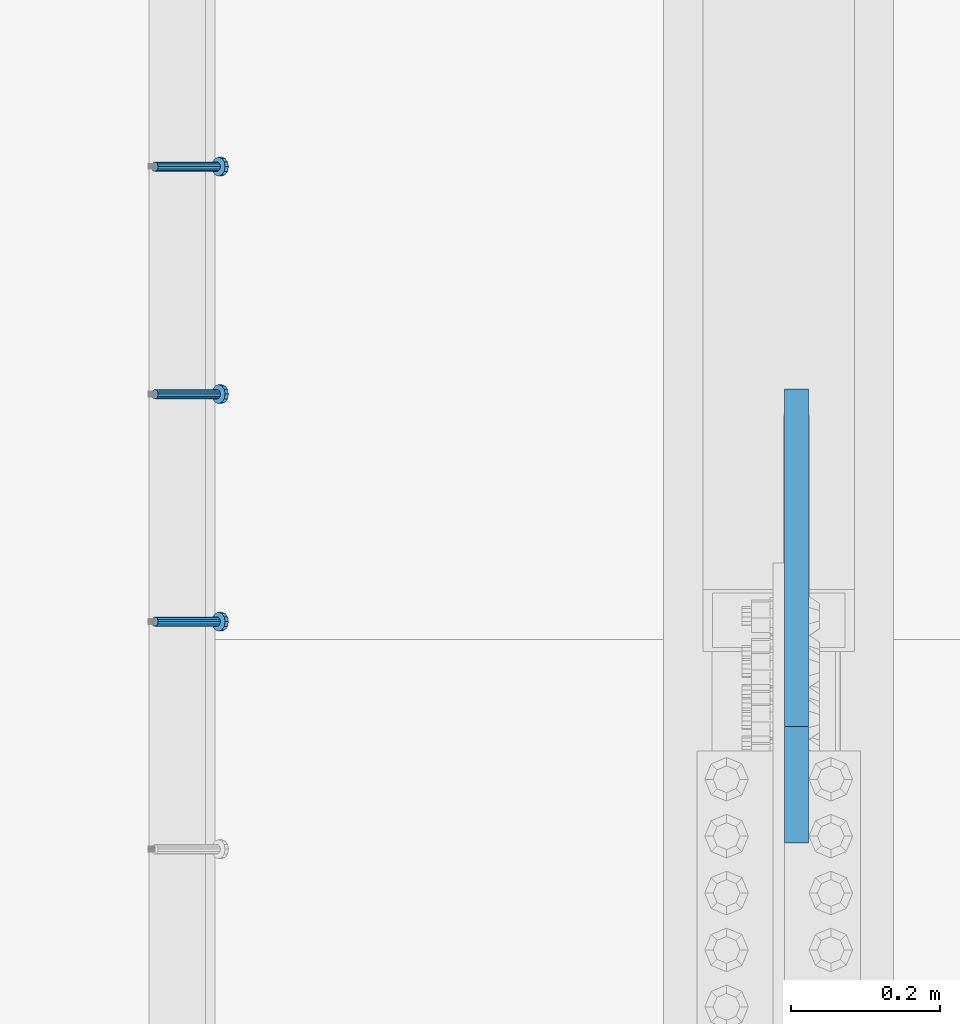
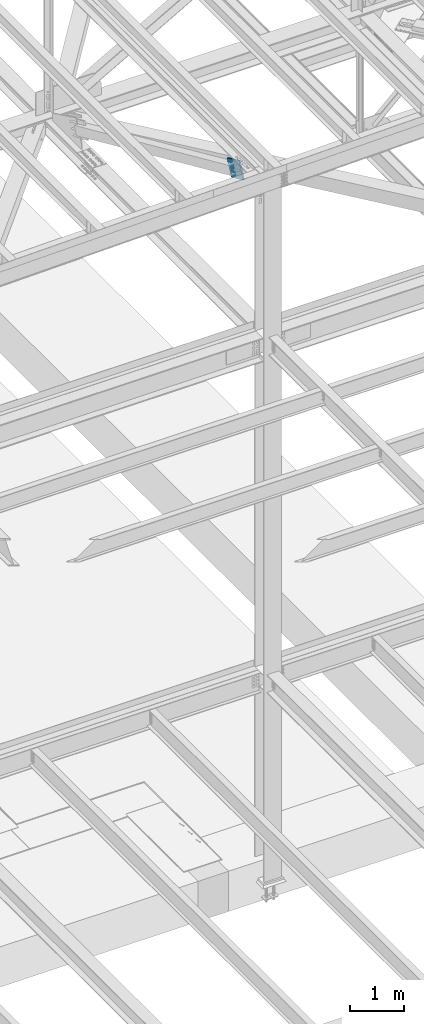
# One storey, part 2170 of 3843: 4 members, 2 elements without a shape of their own.
"""IFC2X3 building model written with IfcOpenShell, lengths in millimetres."""

from ifc_helpers import new_model, si_unit, frame, origin_with_axes, place, context, subcontext, project, spatial, faceted_brep, material, type_object, element, aggregate, save


model = new_model("IFC2X3")

# Units and contexts
model_context = context("Model", 3, precision=1e-05, world=origin_with_axes())
body_context = subcontext(model_context, "Body", "Model", "MODEL_VIEW")
ifc_project = project(units=[si_unit("LENGTHUNIT", "METRE", prefix="MILLI"), si_unit("AREAUNIT", "SQUARE_METRE"), si_unit("VOLUMEUNIT", "CUBIC_METRE"), si_unit("MASSUNIT", "GRAM", prefix="KILO"), si_unit("TIMEUNIT", "SECOND"), si_unit("PLANEANGLEUNIT", "RADIAN"), si_unit("SOLIDANGLEUNIT", "STERADIAN"), si_unit("THERMODYNAMICTEMPERATUREUNIT", "DEGREE_CELSIUS"), si_unit("LUMINOUSINTENSITYUNIT", "LUMEN")], contexts=[model_context])

# Site, building, storey
site_placement = place(None, origin_with_axes())
site = spatial("IfcSite", under=ifc_project, at=site_placement, CompositionType="ELEMENT")
building_placement = place(site_placement, origin_with_axes())
building = spatial("IfcBuilding", under=site, at=building_placement, Name="Undefined", CompositionType="ELEMENT")
storey_placement = place(building_placement, origin_with_axes())
storey = spatial("IfcBuildingStorey", under=building, at=storey_placement, Name="Undefined", CompositionType="ELEMENT", Elevation=0.0)

# Assembly, members
assembly_1_placement = place(storey_placement, origin_with_axes())
assembly_1 = element("IfcElementAssembly", 1, at=assembly_1_placement, inside=storey, Name="EMBED_ANGLE", AssemblyPlace="NOTDEFINED", PredefinedType="RIGID_FRAME")
ifc_material_1 = material(Name="STEEL/A108")
member_type_1 = type_object("IfcMemberType", PredefinedType="NOTDEFINED")
member_1_placement = place(assembly_1_placement, frame((69420.5494374184, 27458.9875018083, 30446.6625), z_axis=(0.0, 1.0, 0.0), x_axis=(0.707106781186548, 0.0, -0.707106781186548)))
member_1 = element("IfcMember", 2, at=member_1_placement, type_object=member_type_1, material=ifc_material_1, Name="HEADED STUD ANCHOR", context=body_context, shape_type="Brep", body=[
    faceted_brep([(7.27595761418343e-12, -3.18000006675175, 5.5), (0.0, -5.49999999998363, 3.1800000667572), (118.110000000976, -5.49999999999091, 3.1800000667572), (118.110000000983, -3.18000006675175, 5.5), (0.0, -6.3499999046162, 0.0), (118.110000000968, -6.34999990461256, 0.0), (0.0, -5.49999999998363, -3.1800000667572), (118.110000000976, -5.49999999999091, -3.1800000667572), (7.27595761418343e-12, -3.18000006675175, -5.5), (118.110000000983, -3.18000006675175, -5.5), (7.27595761418343e-12, -1.81898940354586e-12, -6.34999990463257), (118.110000000968, -1.81898940354586e-12, -6.34999990463257), (0.0, 3.18000006675175, -5.5), (118.110000000968, 3.18000006674811, -5.5), (7.27595761418343e-12, 5.49999999998363, -3.1800000667572), (118.110000000983, 5.49999999998363, -3.1800000667572), (7.27595761418343e-12, 6.3499999046162, 0.0), (118.110000000976, 6.34999990461256, 0.0), (7.27595761418343e-12, 5.49999999998363, 3.1800000667572), (118.110000000983, 5.49999999998363, 3.1800000667572), (0.0, 3.18000006675175, 5.5), (118.110000000968, 3.18000006674811, 5.5), (7.27595761418343e-12, -1.81898940354586e-12, 6.34999990463257), (118.110000000968, -1.81898940354586e-12, 6.34999990463257), (120.650000000991, -10.9899997710909, 6.34999990463257), (120.650000000998, -6.34000015257152, 10.9899997711182), (120.650000000991, -12.6999998092379, 0.0), (120.650000000991, -10.9899997710909, -6.34999990463257), (120.650000000998, -6.34000015257152, -10.9899997711182), (120.650000000991, -1.81898940354586e-12, -12.6899995803833), (120.650000000991, 6.34000015257152, -10.9899997711182), (120.650000000998, 10.9899997710909, -6.34999990463257), (120.650000000991, 12.6999998092342, 0.0), (120.650000000998, 10.9899997710909, 6.34999990463257), (120.650000000991, 6.34000015257152, 10.9899997711182), (120.650000000991, -1.81898940354586e-12, 12.6899995803833), (127.000000001048, -10.9899997710945, 6.34999990463257), (127.000000001048, -6.34000015257152, 10.9899997711182), (127.000000001048, -12.6999998092342, 0.0), (127.000000001048, -10.9899997710945, -6.34999990463257), (127.000000001048, -6.34000015257152, -10.9899997711182), (127.000000001048, 1.81898940354586e-12, -12.6899995803833), (127.000000001048, 6.34000015256788, -10.9899997711182), (127.000000001048, 10.9899997710909, -6.34999990463257), (127.000000001048, 12.6999998092379, 0.0), (127.000000001048, 10.9899997710909, 6.34999990463257), (127.000000001048, 6.34000015256788, 10.9899997711182), (127.000000001048, 1.81898940354586e-12, 12.6899995803833)], [[[0, 1, 2, 3]], [[1, 4, 5, 2]], [[4, 6, 7, 5]], [[6, 8, 9, 7]], [[8, 10, 11, 9]], [[10, 12, 13, 11]], [[12, 14, 15, 13]], [[14, 16, 17, 15]], [[16, 18, 19, 17]], [[18, 20, 21, 19]], [[20, 22, 23, 21]], [[22, 0, 3, 23]], [[22, 20, 18, 16, 14, 12, 10, 8, 6, 4, 1, 0]], [[3, 2, 24, 25]], [[2, 5, 26, 24]], [[5, 7, 27, 26]], [[7, 9, 28, 27]], [[9, 11, 29, 28]], [[11, 13, 30, 29]], [[13, 15, 31, 30]], [[15, 17, 32, 31]], [[17, 19, 33, 32]], [[19, 21, 34, 33]], [[21, 23, 35, 34]], [[23, 3, 25, 35]], [[25, 24, 36, 37]], [[24, 26, 38, 36]], [[26, 27, 39, 38]], [[27, 28, 40, 39]], [[28, 29, 41, 40]], [[29, 30, 42, 41]], [[30, 31, 43, 42]], [[31, 32, 44, 43]], [[32, 33, 45, 44]], [[33, 34, 46, 45]], [[34, 35, 47, 46]], [[35, 25, 37, 47]], [[38, 39, 40, 41, 42, 43, 44, 45, 46, 47, 37, 36]]]),
])
member_2_placement = place(assembly_1_placement, frame((69420.5494374184, 27154.1875018083, 30446.6625), z_axis=(0.0, 1.0, 0.0), x_axis=(0.707106781186548, 0.0, -0.707106781186548)))
member_2 = element("IfcMember", 3, at=member_2_placement, type_object=member_type_1, material=ifc_material_1, Name="HEADED STUD ANCHOR", context=body_context, shape_type="Brep", body=[
    faceted_brep([(7.27595761418343e-12, -3.18000006675175, 5.5), (0.0, -5.49999999998363, 3.1800000667572), (118.110000000976, -5.49999999999091, 3.1800000667572), (118.110000000983, -3.18000006675175, 5.5), (0.0, -6.3499999046162, 0.0), (118.110000000968, -6.34999990461256, 0.0), (0.0, -5.49999999998363, -3.1800000667572), (118.110000000976, -5.49999999999091, -3.1800000667572), (7.27595761418343e-12, -3.18000006675175, -5.5), (118.110000000983, -3.18000006675175, -5.5), (7.27595761418343e-12, -1.81898940354586e-12, -6.34999990463257), (118.110000000968, -1.81898940354586e-12, -6.34999990463257), (0.0, 3.18000006675175, -5.5), (118.110000000968, 3.18000006674811, -5.5), (7.27595761418343e-12, 5.49999999998363, -3.1800000667572), (118.110000000983, 5.49999999998363, -3.1800000667572), (7.27595761418343e-12, 6.3499999046162, 0.0), (118.110000000976, 6.34999990461256, 0.0), (7.27595761418343e-12, 5.49999999998363, 3.1800000667572), (118.110000000983, 5.49999999998363, 3.1800000667572), (0.0, 3.18000006675175, 5.5), (118.110000000968, 3.18000006674811, 5.5), (7.27595761418343e-12, -1.81898940354586e-12, 6.34999990463257), (118.110000000968, -1.81898940354586e-12, 6.34999990463257), (120.650000000991, -10.9899997710909, 6.34999990463257), (120.650000000998, -6.34000015257152, 10.9899997711182), (120.650000000991, -12.6999998092379, 0.0), (120.650000000991, -10.9899997710909, -6.34999990463257), (120.650000000998, -6.34000015257152, -10.9899997711182), (120.650000000991, -1.81898940354586e-12, -12.6899995803833), (120.650000000991, 6.34000015257152, -10.9899997711182), (120.650000000998, 10.9899997710909, -6.34999990463257), (120.650000000991, 12.6999998092342, 0.0), (120.650000000998, 10.9899997710909, 6.34999990463257), (120.650000000991, 6.34000015257152, 10.9899997711182), (120.650000000991, -1.81898940354586e-12, 12.6899995803833), (127.000000001048, -10.9899997710945, 6.34999990463257), (127.000000001048, -6.34000015257152, 10.9899997711182), (127.000000001048, -12.6999998092342, 0.0), (127.000000001048, -10.9899997710945, -6.34999990463257), (127.000000001048, -6.34000015257152, -10.9899997711182), (127.000000001048, 1.81898940354586e-12, -12.6899995803833), (127.000000001048, 6.34000015256788, -10.9899997711182), (127.000000001048, 10.9899997710909, -6.34999990463257), (127.000000001048, 12.6999998092379, 0.0), (127.000000001048, 10.9899997710909, 6.34999990463257), (127.000000001048, 6.34000015256788, 10.9899997711182), (127.000000001048, 1.81898940354586e-12, 12.6899995803833)], [[[0, 1, 2, 3]], [[1, 4, 5, 2]], [[4, 6, 7, 5]], [[6, 8, 9, 7]], [[8, 10, 11, 9]], [[10, 12, 13, 11]], [[12, 14, 15, 13]], [[14, 16, 17, 15]], [[16, 18, 19, 17]], [[18, 20, 21, 19]], [[20, 22, 23, 21]], [[22, 0, 3, 23]], [[22, 20, 18, 16, 14, 12, 10, 8, 6, 4, 1, 0]], [[3, 2, 24, 25]], [[2, 5, 26, 24]], [[5, 7, 27, 26]], [[7, 9, 28, 27]], [[9, 11, 29, 28]], [[11, 13, 30, 29]], [[13, 15, 31, 30]], [[15, 17, 32, 31]], [[17, 19, 33, 32]], [[19, 21, 34, 33]], [[21, 23, 35, 34]], [[23, 3, 25, 35]], [[25, 24, 36, 37]], [[24, 26, 38, 36]], [[26, 27, 39, 38]], [[27, 28, 40, 39]], [[28, 29, 41, 40]], [[29, 30, 42, 41]], [[30, 31, 43, 42]], [[31, 32, 44, 43]], [[32, 33, 45, 44]], [[33, 34, 46, 45]], [[34, 35, 47, 46]], [[35, 25, 37, 47]], [[38, 39, 40, 41, 42, 43, 44, 45, 46, 47, 37, 36]]]),
])
member_3_placement = place(assembly_1_placement, frame((69420.5494374184, 26849.3875018083, 30446.6625), z_axis=(0.0, 1.0, 0.0), x_axis=(0.707106781186548, 0.0, -0.707106781186548)))
member_3 = element("IfcMember", 4, at=member_3_placement, type_object=member_type_1, material=ifc_material_1, Name="HEADED STUD ANCHOR", context=body_context, shape_type="Brep", body=[
    faceted_brep([(7.27595761418343e-12, -3.18000006675175, 5.5), (0.0, -5.49999999998363, 3.1800000667572), (118.110000000976, -5.49999999999091, 3.1800000667572), (118.110000000983, -3.18000006675175, 5.5), (0.0, -6.3499999046162, 0.0), (118.110000000968, -6.34999990461256, 0.0), (0.0, -5.49999999998363, -3.1800000667572), (118.110000000976, -5.49999999999091, -3.1800000667572), (7.27595761418343e-12, -3.18000006675175, -5.5), (118.110000000983, -3.18000006675175, -5.5), (7.27595761418343e-12, -1.81898940354586e-12, -6.34999990463257), (118.110000000968, -1.81898940354586e-12, -6.34999990463257), (0.0, 3.18000006675175, -5.5), (118.110000000968, 3.18000006674811, -5.5), (7.27595761418343e-12, 5.49999999998363, -3.1800000667572), (118.110000000983, 5.49999999998363, -3.1800000667572), (7.27595761418343e-12, 6.3499999046162, 0.0), (118.110000000976, 6.34999990461256, 0.0), (7.27595761418343e-12, 5.49999999998363, 3.1800000667572), (118.110000000983, 5.49999999998363, 3.1800000667572), (0.0, 3.18000006675175, 5.5), (118.110000000968, 3.18000006674811, 5.5), (7.27595761418343e-12, -1.81898940354586e-12, 6.34999990463257), (118.110000000968, -1.81898940354586e-12, 6.34999990463257), (120.650000000991, -10.9899997710909, 6.34999990463257), (120.650000000998, -6.34000015257152, 10.9899997711182), (120.650000000991, -12.6999998092379, 0.0), (120.650000000991, -10.9899997710909, -6.34999990463257), (120.650000000998, -6.34000015257152, -10.9899997711182), (120.650000000991, -1.81898940354586e-12, -12.6899995803833), (120.650000000991, 6.34000015257152, -10.9899997711182), (120.650000000998, 10.9899997710909, -6.34999990463257), (120.650000000991, 12.6999998092342, 0.0), (120.650000000998, 10.9899997710909, 6.34999990463257), (120.650000000991, 6.34000015257152, 10.9899997711182), (120.650000000991, -1.81898940354586e-12, 12.6899995803833), (127.000000001048, -10.9899997710945, 6.34999990463257), (127.000000001048, -6.34000015257152, 10.9899997711182), (127.000000001048, -12.6999998092342, 0.0), (127.000000001048, -10.9899997710945, -6.34999990463257), (127.000000001048, -6.34000015257152, -10.9899997711182), (127.000000001048, 1.81898940354586e-12, -12.6899995803833), (127.000000001048, 6.34000015256788, -10.9899997711182), (127.000000001048, 10.9899997710909, -6.34999990463257), (127.000000001048, 12.6999998092379, 0.0), (127.000000001048, 10.9899997710909, 6.34999990463257), (127.000000001048, 6.34000015256788, 10.9899997711182), (127.000000001048, 1.81898940354586e-12, 12.6899995803833)], [[[0, 1, 2, 3]], [[1, 4, 5, 2]], [[4, 6, 7, 5]], [[6, 8, 9, 7]], [[8, 10, 11, 9]], [[10, 12, 13, 11]], [[12, 14, 15, 13]], [[14, 16, 17, 15]], [[16, 18, 19, 17]], [[18, 20, 21, 19]], [[20, 22, 23, 21]], [[22, 0, 3, 23]], [[22, 20, 18, 16, 14, 12, 10, 8, 6, 4, 1, 0]], [[3, 2, 24, 25]], [[2, 5, 26, 24]], [[5, 7, 27, 26]], [[7, 9, 28, 27]], [[9, 11, 29, 28]], [[11, 13, 30, 29]], [[13, 15, 31, 30]], [[15, 17, 32, 31]], [[17, 19, 33, 32]], [[19, 21, 34, 33]], [[21, 23, 35, 34]], [[23, 3, 25, 35]], [[25, 24, 36, 37]], [[24, 26, 38, 36]], [[26, 27, 39, 38]], [[27, 28, 40, 39]], [[28, 29, 41, 40]], [[29, 30, 42, 41]], [[30, 31, 43, 42]], [[31, 32, 44, 43]], [[32, 33, 45, 44]], [[33, 34, 46, 45]], [[34, 35, 47, 46]], [[35, 25, 37, 47]], [[38, 39, 40, 41, 42, 43, 44, 45, 46, 47, 37, 36]]]),
])
aggregate(assembly_1, [member_1, member_2, member_3])

# Assembly, member
assembly_2_placement = place(storey_placement, origin_with_axes())
assembly_2 = element("IfcElementAssembly", 5, at=assembly_2_placement, inside=storey, AssemblyPlace="NOTDEFINED", PredefinedType="RIGID_FRAME")
ifc_material_2 = material(Name="STEEL/A572-50")
member_type_2 = type_object("IfcMemberType", PredefinedType="NOTDEFINED")
member_4_placement = place(assembly_2_placement, frame((70280.2125, 26630.9805353041, 45495.4662077822), z_axis=(0.0, -0.408904214975198, -0.912577307944657), x_axis=(0.0, 0.912577307944653, -0.408904214975208)))
member_4 = element("IfcMember", 6, at=member_4_placement, type_object=member_type_2, material=ifc_material_2, Name="PLATE", context=body_context, shape_type="Brep", body=[
    faceted_brep([(3.56521923094988e-10, 15.875, -190.500000000146), (-3.61978891305625e-10, 15.875, 190.500000000153), (495.299999995012, 15.875, 190.500000001084), (495.299999995726, 15.875, -190.499999999221), (-3.61978891305625e-10, -15.875, 190.500000000153), (495.299999995012, -15.875, 190.500000001084), (3.56521923094988e-10, -15.875, -190.500000000146), (495.299999995726, -15.875, -190.499999999221)], [[[0, 1, 2, 3]], [[1, 4, 5, 2]], [[4, 6, 7, 5]], [[6, 0, 3, 7]], [[5, 7, 3, 2]], [[6, 4, 1, 0]]]),
])
aggregate(assembly_2, [member_4])

save(model, "model.ifc")
